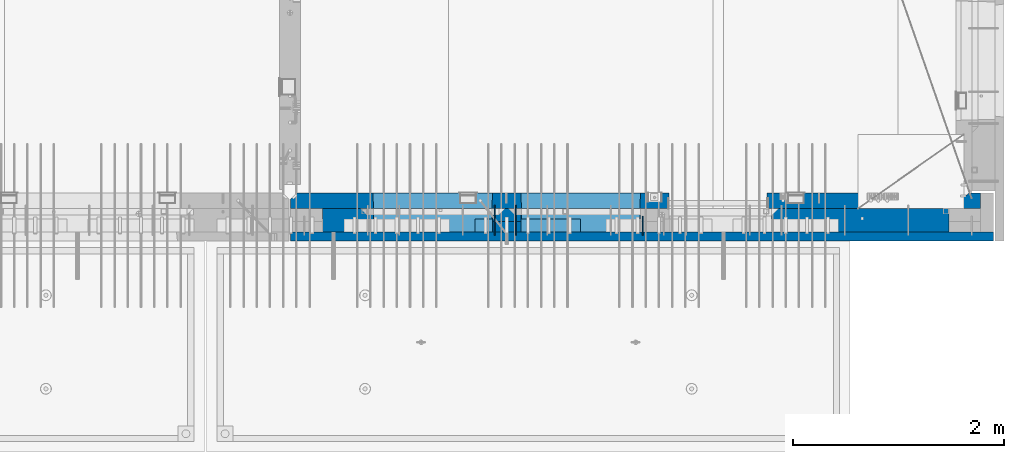
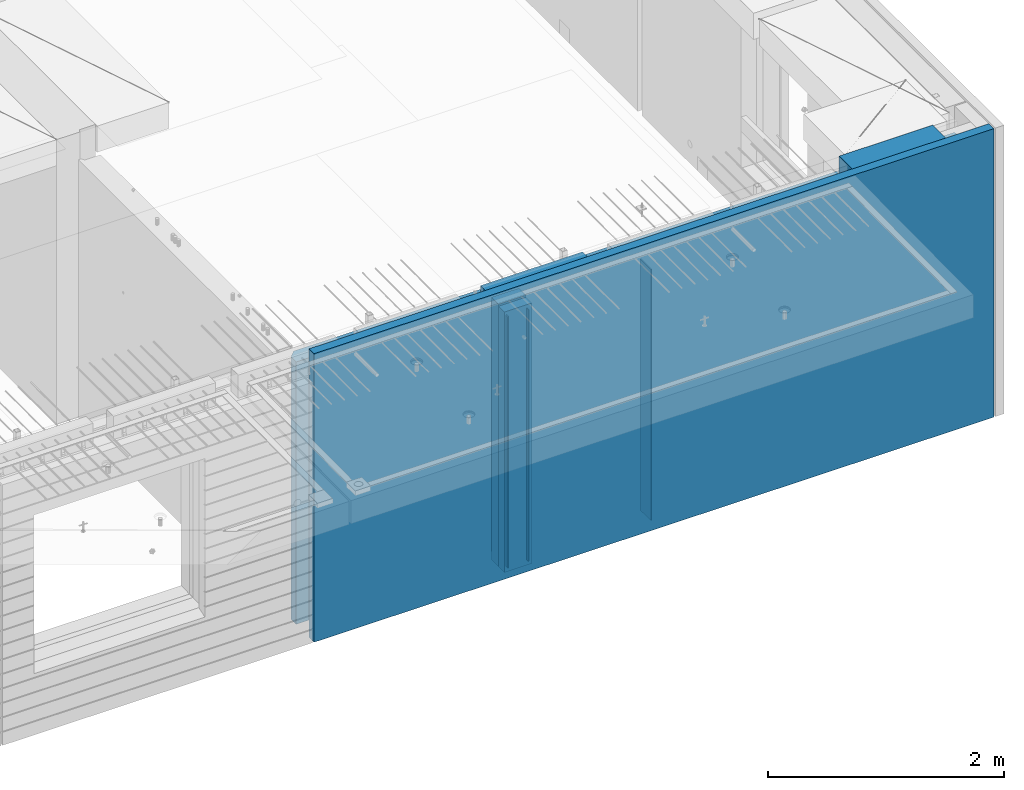
# One storey, part 234 of 350: 9 walls, 6 elements without a shape of their own.
"""IFC2X3 building model written with IfcOpenShell, lengths in millimetres."""

from ifc_helpers import new_model, si_unit, frame, origin_with_axes, place, context, subcontext, project, spatial, faceted_brep, material, type_object, element, aggregate, save


model = new_model("IFC2X3")

# Units and contexts
model_context = context("Model", 3, precision=1e-05, world=origin_with_axes())
body_context = subcontext(model_context, "Body", "Model", "MODEL_VIEW")
ifc_project = project(units=[si_unit("LENGTHUNIT", "METRE", prefix="MILLI"), si_unit("AREAUNIT", "SQUARE_METRE"), si_unit("VOLUMEUNIT", "CUBIC_METRE"), si_unit("MASSUNIT", "GRAM", prefix="KILO"), si_unit("TIMEUNIT", "SECOND"), si_unit("PLANEANGLEUNIT", "RADIAN"), si_unit("SOLIDANGLEUNIT", "STERADIAN"), si_unit("THERMODYNAMICTEMPERATUREUNIT", "DEGREE_CELSIUS"), si_unit("LUMINOUSINTENSITYUNIT", "LUMEN")], contexts=[model_context])

# Site, building, storey
site_placement = place(None, origin_with_axes())
site = spatial("IfcSite", under=ifc_project, at=site_placement, CompositionType="ELEMENT")
building_placement = place(site_placement, origin_with_axes())
building = spatial("IfcBuilding", under=site, at=building_placement, CompositionType="ELEMENT")
storey_placement = place(building_placement, origin_with_axes())
storey = spatial("IfcBuildingStorey", under=building, at=storey_placement, Name="2", CompositionType="ELEMENT", Elevation=0.0)

# Assembly, wall
assembly_1_placement = place(storey_placement, origin_with_axes())
assembly_1 = element("IfcElementAssembly", 1, at=assembly_1_placement, inside=storey, Name="Steel Assembly", AssemblyPlace="NOTDEFINED", PredefinedType="NOTDEFINED")
ifc_material_1 = material(Name="Undefined")
wall_type_1 = type_object("IfcWallType", PredefinedType="NOTDEFINED")
wall_1_placement = place(assembly_1_placement, frame((31944.9998946285, 7780.0, 86115.0), z_axis=(0.0, 0.0, 1.0), x_axis=(0.0, -1.0, 0.0)))
wall_1 = element("IfcWall", 2, at=wall_1_placement, type_object=wall_type_1, material=ifc_material_1, Name="(PD)", context=body_context, shape_type="Brep", body=[
    faceted_brep([(0.0, 5.0, -1300.0), (0.0, 5.0, 1300.0), (180.0, 5.0, 1300.0), (180.0, 5.0, -1300.0), (0.0, -5.0, 1300.0), (180.0, -5.0, 1300.0), (0.0, -5.0, -1300.0), (180.0, -5.0, -1300.0)], [[[0, 1, 2, 3]], [[1, 4, 5, 2]], [[4, 6, 7, 5]], [[6, 0, 3, 7]], [[5, 7, 3, 2]], [[6, 4, 1, 0]]]),
])
aggregate(assembly_1, [wall_1])

assembly_2_placement = place(storey_placement, origin_with_axes())
assembly_2 = element("IfcElementAssembly", 3, at=assembly_2_placement, inside=storey, Name="Steel Assembly", AssemblyPlace="NOTDEFINED", PredefinedType="NOTDEFINED")
wall_2_placement = place(assembly_2_placement, frame((30545.0021834468, 7880.0, 86115.0), z_axis=(0.0, 0.0, 1.0), x_axis=(0.0, -1.0, 0.0)))
wall_2 = element("IfcWall", 4, at=wall_2_placement, type_object=wall_type_1, material=ifc_material_1, Name="(PD)", context=body_context, shape_type="Brep", body=[
    faceted_brep([(0.0, 5.0, -1300.0), (0.0, 5.0, 1300.0), (280.0, 5.0, 1300.0), (280.0, 5.0, -1300.0), (0.0, -5.0, 1300.0), (280.0, -5.0, 1300.0), (0.0, -5.0, -1300.0), (280.0, -5.0, -1300.0)], [[[0, 1, 2, 3]], [[1, 4, 5, 2]], [[4, 6, 7, 5]], [[6, 0, 3, 7]], [[5, 7, 3, 2]], [[6, 4, 1, 0]]]),
])
aggregate(assembly_2, [wall_2])

assembly_3_placement = place(storey_placement, origin_with_axes())
assembly_3 = element("IfcElementAssembly", 5, at=assembly_3_placement, inside=storey, Name="Steel Assembly", AssemblyPlace="NOTDEFINED", PredefinedType="NOTDEFINED")
wall_3_placement = place(assembly_3_placement, frame((30745.0021834468, 7880.0, 86115.0), z_axis=(0.0, 0.0, 1.0), x_axis=(0.0, -1.0, 0.0)))
wall_3 = element("IfcWall", 6, at=wall_3_placement, type_object=wall_type_1, material=ifc_material_1, Name="(PD)", context=body_context, shape_type="Brep", body=[
    faceted_brep([(0.0, 5.0, -1300.0), (0.0, 5.0, 1300.0), (280.0, 5.0, 1300.0), (280.0, 5.0, -1300.0), (0.0, -5.0, 1300.0), (280.0, -5.0, 1300.0), (0.0, -5.0, -1300.0), (280.0, -5.0, -1300.0)], [[[0, 1, 2, 3]], [[1, 4, 5, 2]], [[4, 6, 7, 5]], [[6, 0, 3, 7]], [[5, 7, 3, 2]], [[6, 4, 1, 0]]]),
])
aggregate(assembly_3, [wall_3])

# Assemblies, wall
assembly_4_placement = place(storey_placement, origin_with_axes())
assembly_4 = element("IfcElementAssembly", 7, at=assembly_4_placement, inside=storey, AssemblyPlace="NOTDEFINED", PredefinedType="REINFORCEMENT_UNIT")
assembly_5_placement = place(assembly_4_placement, origin_with_axes())
assembly_5 = element("IfcElementAssembly", 8, at=assembly_5_placement, Name="Steel Assembly", AssemblyPlace="NOTDEFINED", PredefinedType="NOTDEFINED")
aggregate(assembly_4, [assembly_5])
ifc_material_2 = material()
wall_type_2 = type_object("IfcWallType", PredefinedType="NOTDEFINED")
wall_4_placement = place(assembly_5_placement, frame((30359.9998568133, 7690.00021946163, 87590.0), z_axis=(0.0, 0.0, 1.0), x_axis=(1.0, 0.0, 0.0)))
wall_4 = element("IfcWall", 9, at=wall_4_placement, type_object=wall_type_2, material=ifc_material_2, context=body_context, shape_type="Brep", body=[
    faceted_brep([(0.0, 60.0, -120.0), (0.0, 60.0, 120.0), (1000.0, 60.0, 120.0), (1000.0, 60.0, -120.0), (0.0, -60.0, 120.0), (1000.0, -60.0, 120.0), (0.0, -60.0, -120.0), (1000.0, -60.0, -120.0)], [[[0, 1, 2, 3]], [[1, 4, 5, 2]], [[4, 6, 7, 5]], [[6, 0, 3, 7]], [[5, 7, 3, 2]], [[6, 4, 1, 0]]]),
])
aggregate(assembly_5, [wall_4])

# Assembly, walls
assembly_6_placement = place(storey_placement, origin_with_axes())
assembly_6 = element("IfcElementAssembly", 10, at=assembly_6_placement, inside=storey, AssemblyPlace="NOTDEFINED", PredefinedType="REINFORCEMENT_UNIT")
ifc_material_3 = material(Name="COS5gt")
wall_type_3 = type_object("IfcWallType", PredefinedType="NOTDEFINED")
wall_5_placement = place(assembly_6_placement, frame((34845.0, 7740.0, 86247.5), z_axis=(0.0, 0.0, 1.0), x_axis=(-1.0, 3.00000001838171e-08, 0.0)))
wall_5 = element("IfcWall", 11, at=wall_5_placement, type_object=wall_type_3, material=ifc_material_3, context=body_context, shape_type="Brep", body=[
    faceted_brep([(916.999863502781, 109.965786274794, 1152.5), (917.000000002787, 89.9657862752601, 1152.5), (2649.99996185248, 89.9776140000004, 1152.5), (2649.99996185248, 110.0, 1152.5), (917.000000002787, 89.9657862752601, 1202.5), (917.0, 110.0, 1202.5), (2649.99996185248, 89.9776140000004, 1202.5), (0.0, 110.0, 1492.5), (0.0, -110.0, 1492.5), (917.0, -110.0, 1492.5), (917.0, 110.0, 1492.5), (0.0, -110.0, -1492.5), (0.0, 90.0, -1492.5), (1680.00110766775, 90.0, -1492.5), (1680.00110766775, -110.0, -1492.5), (0.0, 90.0, -1442.5), (1680.00110766775, 90.0, -1442.5), (0.0, 110.0, -1442.5), (1680.00110766775, 110.0, -1442.5), (1680.00110766775, 110.0, 857.5), (1680.00110766775, -110.0, 857.5), (2649.99996185248, 110.0, 857.5), (2649.99996185248, -10.0, 857.5), (2649.99996185248, -110.0, 857.5), (2649.99996185248, -110.0, 1202.5), (2649.99996185248, -10.0, 1202.5), (917.0, -110.0, 1202.5), (2920.0018706072, 89.9794567630279, 1152.5), (4049.99996185248, 89.987169, 1152.5), (4049.99996185248, 110.0, 1152.5), (2920.0018706072, 110.0, 1152.5), (2920.0018706072, 89.9794567630279, 1202.5), (4049.99996185248, 89.987169, 1202.5), (2920.0018706072, 110.0, -1442.5), (2920.0018706072, 90.0, -1442.5), (2920.0018706072, 90.0, -1492.5), (2920.0018706072, -10.0, -1492.5), (2920.0018706072, -10.0, 1202.5), (4049.99996185248, 110.0, -1442.5), (4049.99996185248, 90.0, -1442.5), (4049.99996185248, 90.0, -1492.5), (4049.99996185248, -110.0, 1202.5), (4049.99996185248, -110.0, -1492.5), (4049.99996185248, -10.0, -1492.5), (4049.99996185248, -10.0, 1202.5), (2920.0018706072, -110.0, -1492.5), (2920.0018706072, -110.0, 1202.5), (4045.94781655315, -110.0, -813.445945945947), (4040.0018706072, 110.0, -807.5), (4010.0018706072, 110.0, -807.5), (2960.0018706072, 110.0, -807.5), (2930.0018706072, 110.0, -807.5), (2924.05592466125, -110.0, -813.445945945947), (2924.05592466125, -110.0, 813.445945945947), (4045.94781655315, -110.0, 813.445945945947), (4040.0018706072, 110.0, -802.5), (4040.0018706072, 110.0, 807.5), (2930.0018706072, 110.0, 807.5), (2930.0018706072, 110.0, -802.5), (4320.0018706072, 89.9890117630275, 1152.5), (5929.99996185248, 90.0, 1152.5), (5930.0, 110.0, 1152.5), (4320.0018706072, 110.0, 1152.5), (4320.0018706072, 89.9890117630275, 1202.5), (5930.0, 90.0, 1202.5), (5928.5, 90.0, -1442.5), (5928.5, 90.0, -1492.5), (4320.0018706072, 90.0, -1492.5), (4320.0018706072, 90.0, -1442.5), (4320.0018706072, 110.0, -1442.5), (4320.0018706072, -10.0, -1492.5), (4320.0018706072, -10.0, 1202.5), (5928.5, 110.0, -1442.5), (5928.5, 110.0, -1492.5), (5930.0, 110.0, -1492.5), (5930.0, -110.0, -1492.5), (4320.0018706072, -110.0, -1492.5), (4320.0018706072, -110.0, 1202.5), (5445.94552773479, -110.0, -813.445945945947), (5439.99958178884, 110.0, -807.5), (5409.99958178884, 110.0, -807.5), (4359.99958178884, 110.0, -807.5), (4329.99958178884, 110.0, -807.5), (4324.05363584289, -110.0, -813.445945945947), (5930.0, -110.0, 1202.5), (4324.05363584289, -110.0, 813.445945945947), (5445.94552773479, -110.0, 813.445945945947), (5439.99958178884, 110.0, -802.5), (5439.99958178884, 110.0, 807.5), (4329.99958178884, 110.0, 807.5), (4329.99958178884, 110.0, -802.5)], [[[0, 1, 2, 3]], [[4, 1, 0, 5]], [[6, 2, 1, 4]], [[7, 8, 9, 10]], [[11, 12, 13, 14]], [[12, 15, 16, 13]], [[12, 11, 8, 7, 17, 15]], [[15, 17, 18, 16]], [[14, 13, 16, 18, 19, 20]], [[20, 19, 21, 22, 23]], [[24, 23, 22, 25]], [[26, 9, 8, 11, 14, 20, 23, 24]], [[10, 9, 26, 4, 5]], [[3, 21, 19, 18, 17, 7, 10, 5, 0]], [[25, 22, 21, 3, 2, 6]], [[26, 24, 25, 6, 4]], [[27, 28, 29, 30]], [[31, 32, 28, 27]], [[30, 33, 34, 35, 36, 37, 31, 27]], [[34, 33, 38, 39]], [[35, 34, 39, 40]], [[41, 42, 43, 44]], [[35, 40, 43, 42, 45, 36]], [[46, 37, 36, 45]], [[47, 48, 49, 50, 51, 52]], [[42, 41, 46, 45], [47, 52, 53, 54]], [[55, 48, 47, 54, 56]], [[53, 57, 56, 54]], [[52, 51, 58, 57, 53]], [[38, 33, 30, 29], [51, 50, 49, 48, 55, 56, 57, 58]], [[44, 43, 40, 39, 38, 29, 28, 32]], [[37, 46, 41, 44, 32, 31]], [[59, 60, 61, 62]], [[63, 64, 60, 59]], [[65, 66, 67, 68]], [[62, 69, 68, 67, 70, 71, 63, 59]], [[72, 65, 68, 69]], [[66, 65, 72, 73]], [[67, 66, 73, 74, 75, 76, 70]], [[77, 71, 70, 76]], [[78, 79, 80, 81, 82, 83]], [[75, 84, 77, 76], [78, 83, 85, 86]], [[87, 79, 78, 86, 88]], [[85, 89, 88, 86]], [[83, 82, 90, 89, 85]], [[74, 73, 72, 69, 62, 61], [82, 81, 80, 79, 87, 88, 89, 90]], [[84, 75, 74, 61, 60, 64]], [[71, 77, 84, 64, 63]]]),
])
ifc_material_4 = material(Name="CONCRETE/C30/37")
wall_type_4 = type_object("IfcWallType", PredefinedType="NOTDEFINED")
wall_6_placement = place(assembly_6_placement, frame((35265.0, 7587.5, 86247.5), z_axis=(0.0, 0.0, 1.0), x_axis=(-1.0, 3.00000001838171e-08, 0.0)))
wall_6 = element("IfcWall", 12, at=wall_6_placement, type_object=wall_type_4, material=ifc_material_4, context=body_context, shape_type="Brep", body=[
    faceted_brep([(0.0, 42.5, -1492.5), (0.0, 42.5, 1492.5), (6650.0, 42.5, 1492.5), (6650.0, 42.5, -1492.5), (0.0, -42.5, 1492.5), (6650.0, -42.5, 1492.5), (0.0, -42.5, -1492.5), (6650.0, -42.5, -1492.5)], [[[0, 1, 2, 3]], [[1, 4, 5, 2]], [[4, 6, 7, 5]], [[6, 0, 3, 7]], [[5, 7, 3, 2]], [[6, 4, 1, 0]]]),
])
ifc_material_5 = material(Name="CONCRETE/C35/45")
wall_type_5 = type_object("IfcWallType", PredefinedType="NOTDEFINED")
wall_7_placement = place(assembly_6_placement, frame((35145.0, 7925.0, 86112.5), z_axis=(0.0, 0.0, 1.0), x_axis=(-1.0, 3.00000001838171e-08, 0.0)))
wall_7 = element("IfcWall", 13, at=wall_7_placement, type_object=wall_type_5, material=ifc_material_5, context=body_context, shape_type="Brep", body=[
    faceted_brep([(202.000000451517, -54.9999973486238, 1357.5), (202.000000451517, -54.9999973486238, -1357.5), (214.999999722531, -75.0, -1357.5), (214.999999722531, -75.0, 1357.5), (128.000000410604, -54.9999993903875, 1357.5), (128.000000410604, -54.9999993903875, -1357.5), (115.0, -75.0, 1357.5), (115.0, -75.0, -1357.5), (0.0, -75.0, -1357.5), (0.0, -75.0, 1357.5), (0.0, 75.0, 1357.5), (0.0, 75.0, -1357.5), (6470.0, -75.0, 1357.5), (6530.0, -15.0, 1357.5), (6530.0, 75.0, 1357.5), (6530.0, 75.0, -1357.5), (6530.0, -15.0, -1357.5), (6470.0, -75.0, -1357.5), (2950.00110766775, -75.0, -1357.5), (2946.15495382159, 75.0, -1357.5), (2950.00110766775, -75.0, 952.5), (2946.1549538216, 75.0, 948.653846153844), (2020.00110766775, -75.0, 952.5), (2023.8472615139, 75.0, 948.653846153844), (2020.00110766775, -75.0, -1357.5), (2023.8472615139, 75.0, -1357.5), (5749.99958178884, -75.0, -682.5), (5745.94552773479, 75.0, -678.445945945947), (4624.05363584289, 75.0, -678.445945945947), (4619.99958178884, -75.0, -682.5), (5749.99958178884, -75.0, 952.5), (5745.94552773479, 75.0, 948.445945945947), (4619.99958178884, -75.0, 952.5), (4624.05363584289, 75.0, 948.445945945947), (4345.94781655315, 75.0, -678.445945945947), (4345.94781655315, 75.0, 948.445945945947), (3224.05592466125, 75.0, 948.445945945947), (3224.05592466125, 75.0, -678.445945945947), (3220.0018706072, -75.0, -682.5), (3220.0018706072, -75.0, 952.5), (4350.0018706072, -75.0, -682.5), (4350.0018706072, -75.0, 952.5)], [[[0, 1, 2, 3]], [[4, 5, 1, 0]], [[6, 7, 5, 4]], [[8, 9, 10, 11]], [[0, 3, 12, 13, 14, 10, 9, 6, 4]], [[15, 14, 13, 16]], [[12, 17, 16, 13]], [[15, 16, 17, 18, 19]], [[19, 18, 20, 21]], [[22, 23, 21, 20]], [[24, 25, 23, 22]], [[26, 27, 28, 29]], [[27, 26, 30, 31]], [[32, 33, 31, 30]], [[29, 28, 33, 32]], [[11, 10, 14, 15, 19, 21, 23, 25], [34, 35, 36, 37], [27, 31, 33, 28]], [[38, 37, 36, 39]], [[40, 34, 37, 38]], [[34, 40, 41, 35]], [[39, 36, 35, 41]], [[24, 22, 20, 18, 17, 12, 3, 2], [40, 38, 39, 41], [26, 29, 32, 30]], [[8, 11, 25, 24, 2, 1, 5, 7]], [[9, 8, 7, 6]]]),
])
ifc_material_6 = material(Name="SPU")
wall_type_6 = type_object("IfcWallType", PredefinedType="NOTDEFINED")
wall_8_placement = place(assembly_6_placement, frame((30795.0000381475, 7680.0, 86102.5), z_axis=(0.0, 0.0, 1.0), x_axis=(-1.0, 3.00000001838171e-08, 0.0)))
wall_8 = element("IfcWall", 14, at=wall_8_placement, type_object=wall_type_6, material=ifc_material_6, context=body_context, shape_type="Brep", body=[
    faceted_brep([(0.0, 50.0, -1347.5), (0.0, 50.0, 1347.5), (270.001908754726, 50.0, 1347.5), (270.001908754726, 50.0, -1347.5), (0.0, -50.0, 1347.5), (270.001908754726, -50.0, 1347.5), (0.0, -50.0, -1347.5), (270.001908754726, -50.0, -1347.5)], [[[0, 1, 2, 3]], [[1, 4, 5, 2]], [[4, 6, 7, 5]], [[6, 0, 3, 7]], [[5, 7, 3, 2]], [[6, 4, 1, 0]]]),
])
wall_type_7 = type_object("IfcWallType", PredefinedType="NOTDEFINED")
wall_9_placement = place(assembly_6_placement, frame((30795.0000381475, 7790.0, 86112.5), z_axis=(0.0, 0.0, 1.0), x_axis=(-1.0, 3.00000001838171e-08, 0.0)))
wall_9 = element("IfcWall", 15, at=wall_9_placement, type_object=wall_type_7, material=ifc_material_5, context=body_context, shape_type="Brep", body=[
    faceted_brep([(0.0, 60.0, -1357.5), (0.0, 60.0, 1357.5), (270.001908754726, 60.0, 1357.5), (270.001908754726, 60.0, -1357.5), (0.0, -60.0, 1357.5), (270.001908754726, -60.0, 1357.5), (0.0, -60.0, -1357.5), (270.001908754726, -60.0, -1357.5)], [[[0, 1, 2, 3]], [[1, 4, 5, 2]], [[4, 6, 7, 5]], [[6, 0, 3, 7]], [[5, 7, 3, 2]], [[6, 4, 1, 0]]]),
])
aggregate(assembly_6, [wall_8, wall_9, wall_5, wall_6, wall_7])

save(model, "model.ifc")
